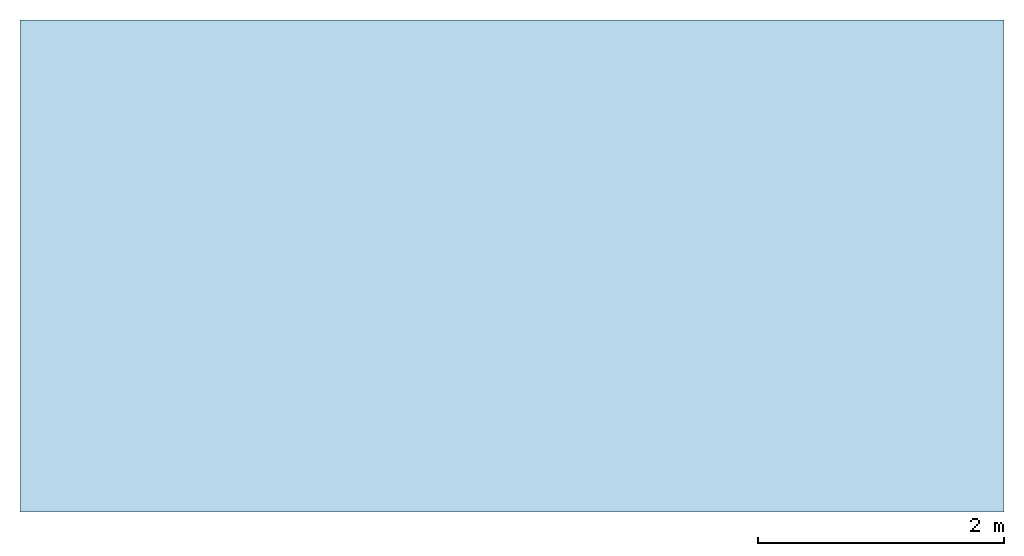
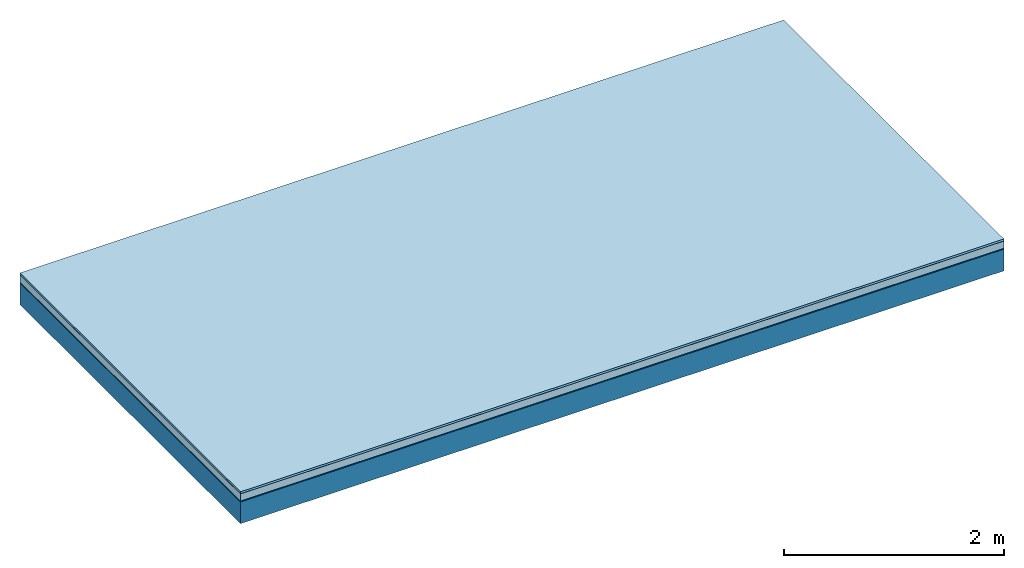
# One storey: 5 plates, 1 member, 1 element without a shape of its own.
"""IFC4 building model written with IfcOpenShell, lengths in metres."""

from ifc_helpers import new_model, si_unit, derived_unit, direction, frame, frame_2d, origin, origin_with_axes, place, context, project, spatial, rectangle, extrude, material, layer, layer_set, type_object, element, aggregate, save


model = new_model("IFC4")

# Units and contexts
plan_context = context("Plan", 3, precision=1e-05, world=origin(), true_north=direction((0.0, 1.0)))
model_context = context("Model", 3, precision=1e-05, world=origin(), true_north=direction((0.0, 1.0)))
ifc_project = project(units=[si_unit("LENGTHUNIT", "METRE"), derived_unit("SOUNDPRESSUREUNIT", [(si_unit("PRESSUREUNIT", "PASCAL", prefix="MICRO"), 0)]), si_unit("ENERGYUNIT", "JOULE", prefix="MEGA"), si_unit("MASSUNIT", "GRAM", prefix="KILO"), derived_unit("THERMALTRANSMITTANCEUNIT", [(si_unit("POWERUNIT", "WATT"), 1), (si_unit("AREAUNIT", "SQUARE_METRE"), -1), (si_unit("THERMODYNAMICTEMPERATUREUNIT", "KELVIN"), -1)]), derived_unit("AREADENSITYUNIT", [(si_unit("MASSUNIT", "GRAM", prefix="KILO"), 1), (si_unit("AREAUNIT", "SQUARE_METRE"), -1)]), derived_unit("USERDEFINED", [(si_unit("ENERGYUNIT", "JOULE", prefix="MEGA"), 1), (si_unit("AREAUNIT", "SQUARE_METRE"), -1)])], contexts=[plan_context, model_context])

# Site, building, storey
site = spatial("IfcSite", under=ifc_project)
building_placement = place(None, origin())
building = spatial("IfcBuilding", under=site, at=building_placement)
storey_placement = place(building_placement, origin())
storey = spatial("IfcBuildingStorey", under=building, at=storey_placement)

# Slab, member, plates
ifc_material_1 = material(Name="with tongue and groove", Category="07.009")
ifc_layer_1 = layer(ifc_material_1, 0.022, Name="Flooring")
ifc_material_2 = material(Category="09.006")
ifc_layer_2 = layer(ifc_material_2, 0.0005, Name="layer")
ifc_material_3 = material(Category="07.011")
ifc_layer_3 = layer(ifc_material_3, 0.08, Name="On-material")
ifc_material_4 = material(Name="Wood fiber generic product", Category="10.009")
ifc_layer_4 = layer(ifc_material_4, 0.01, Name="Impact sound insulation")
ifc_material_5 = material(Name="protection", Category="09.007")
ifc_layer_5 = layer(ifc_material_5, 0.0005, Name="Sub-floor")
ifc_material_6 = material(Name="no composite action")
ifc_layer_6 = layer(ifc_material_6, 0.0, Name="Bond")
ifc_layer_7 = layer(None, 0.24, Name="Supporting structure")
ifc_layer_set = layer_set([ifc_layer_1, ifc_layer_2, ifc_layer_3, ifc_layer_4, ifc_layer_5, ifc_layer_6, ifc_layer_7])
slab_type = type_object("IfcSlabType", Name="A2021", PredefinedType="NOTDEFINED", material=ifc_layer_set)
slab_placement = place(None, frame((0.0, 0.0, 0.0), z_axis=(0.0, 0.0, -1.0), x_axis=(1.0, 0.0, 0.0)))
slab = element("IfcSlab", 1, at=slab_placement, inside=storey, type_object=slab_type, material=ifc_layer_set, Name="Slab #1")
ifc_material_7 = material(Name="Solid timber panel")
member_placement = place(slab_placement, origin())
member = element("IfcMember", 2, at=member_placement, material=ifc_material_7, Name="Supporting structure", context=plan_context, shape_type="SweptSolid", body=[
    extrude(rectangle(XDim=1.0, YDim=0.24, at=frame_2d((0.5, 0.12), x_axis=(1.0, 0.0))), frame((0.0, 4.0, 0.113), z_axis=(0.0, -1.0, 0.0), x_axis=(1.0, 0.0, 0.0)), (0.0, 0.0, 1.0), 4.0),
    extrude(rectangle(XDim=1.0, YDim=0.24, at=frame_2d((0.5, 0.12), x_axis=(1.0, 0.0))), frame((1.0, 4.0, 0.113), z_axis=(0.0, -1.0, 0.0), x_axis=(1.0, 0.0, 0.0)), (0.0, 0.0, 1.0), 4.0),
    extrude(rectangle(XDim=1.0, YDim=0.24, at=frame_2d((0.5, 0.12), x_axis=(1.0, 0.0))), frame((2.0, 4.0, 0.113), z_axis=(0.0, -1.0, 0.0), x_axis=(1.0, 0.0, 0.0)), (0.0, 0.0, 1.0), 4.0),
    extrude(rectangle(XDim=1.0, YDim=0.24, at=frame_2d((0.5, 0.12), x_axis=(1.0, 0.0))), frame((3.0, 4.0, 0.113), z_axis=(0.0, -1.0, 0.0), x_axis=(1.0, 0.0, 0.0)), (0.0, 0.0, 1.0), 4.0),
    extrude(rectangle(XDim=1.0, YDim=0.24, at=frame_2d((0.5, 0.12), x_axis=(1.0, 0.0))), frame((4.0, 4.0, 0.113), z_axis=(0.0, -1.0, 0.0), x_axis=(1.0, 0.0, 0.0)), (0.0, 0.0, 1.0), 4.0),
    extrude(rectangle(XDim=1.0, YDim=0.24, at=frame_2d((0.5, 0.12), x_axis=(1.0, 0.0))), frame((5.0, 4.0, 0.113), z_axis=(0.0, -1.0, 0.0), x_axis=(1.0, 0.0, 0.0)), (0.0, 0.0, 1.0), 4.0),
    extrude(rectangle(XDim=1.0, YDim=0.24, at=frame_2d((0.5, 0.12), x_axis=(1.0, 0.0))), frame((6.0, 4.0, 0.113), z_axis=(0.0, -1.0, 0.0), x_axis=(1.0, 0.0, 0.0)), (0.0, 0.0, 1.0), 4.0),
    extrude(rectangle(XDim=1.0, YDim=0.24, at=frame_2d((0.5, 0.12), x_axis=(1.0, 0.0))), frame((7.0, 4.0, 0.113), z_axis=(0.0, -1.0, 0.0), x_axis=(1.0, 0.0, 0.0)), (0.0, 0.0, 1.0), 4.0),
])
plate_1_placement = place(slab_placement, origin())
plate_1 = element("IfcPlate", 3, at=plate_1_placement, material=ifc_material_1, Name="Flooring", context=plan_context, shape_type="SweptSolid", body=[
    extrude(rectangle(XDim=8.0, YDim=4.0, at=frame_2d((4.0, 2.0), x_axis=(1.0, 0.0))), origin_with_axes(), (0.0, 0.0, 1.0), 0.022),
])
plate_2_placement = place(slab_placement, origin())
plate_2 = element("IfcPlate", 4, at=plate_2_placement, material=ifc_material_2, Name="layer", context=plan_context, shape_type="SweptSolid", body=[
    extrude(rectangle(XDim=8.0, YDim=4.0, at=frame_2d((4.0, 2.0), x_axis=(1.0, 0.0))), frame((0.0, 0.0, 0.022), z_axis=(0.0, 0.0, 1.0), x_axis=(1.0, 0.0, 0.0)), (0.0, 0.0, 1.0), 0.0005),
])
plate_3_placement = place(slab_placement, origin())
plate_3 = element("IfcPlate", 5, at=plate_3_placement, material=ifc_material_3, Name="On-material", context=plan_context, shape_type="SweptSolid", body=[
    extrude(rectangle(XDim=8.0, YDim=4.0, at=frame_2d((4.0, 2.0), x_axis=(1.0, 0.0))), frame((0.0, 0.0, 0.0225), z_axis=(0.0, 0.0, 1.0), x_axis=(1.0, 0.0, 0.0)), (0.0, 0.0, 1.0), 0.08),
])
plate_4_placement = place(slab_placement, origin())
plate_4 = element("IfcPlate", 6, at=plate_4_placement, material=ifc_material_4, Name="Impact sound insulation", context=plan_context, shape_type="SweptSolid", body=[
    extrude(rectangle(XDim=8.0, YDim=4.0, at=frame_2d((4.0, 2.0), x_axis=(1.0, 0.0))), frame((0.0, 0.0, 0.1025), z_axis=(0.0, 0.0, 1.0), x_axis=(1.0, 0.0, 0.0)), (0.0, 0.0, 1.0), 0.01),
])
plate_5_placement = place(slab_placement, origin())
plate_5 = element("IfcPlate", 7, at=plate_5_placement, material=ifc_material_5, Name="Sub-floor", context=plan_context, shape_type="SweptSolid", body=[
    extrude(rectangle(XDim=8.0, YDim=4.0, at=frame_2d((4.0, 2.0), x_axis=(1.0, 0.0))), frame((0.0, 0.0, 0.1125), z_axis=(0.0, 0.0, 1.0), x_axis=(1.0, 0.0, 0.0)), (0.0, 0.0, 1.0), 0.0005),
])
aggregate(slab, [plate_1, plate_2, plate_3, plate_4, plate_5, member])

save(model, "model.ifc")
